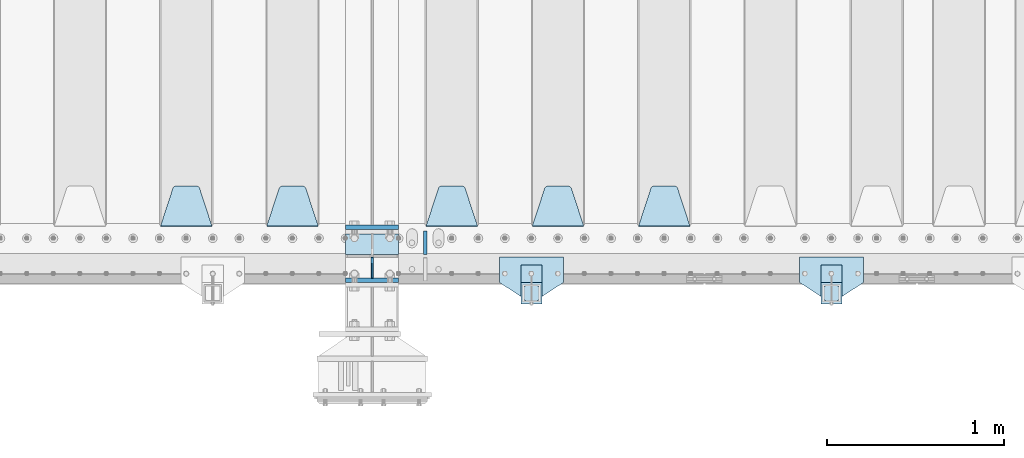
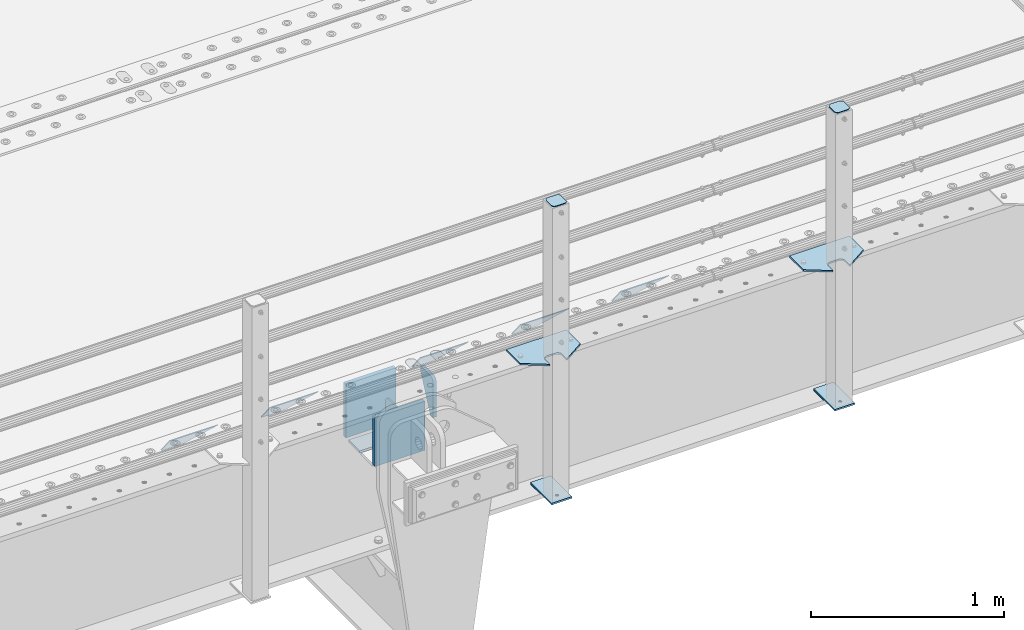
# One storey, part 179 of 208: 18 plates.
"""IFC2X3 building model written with IfcOpenShell, lengths in millimetres."""

from ifc_helpers import new_model, si_unit, frame, origin_with_axes, place, context, subcontext, project, spatial, faceted_brep, material, type_object, element, save


model = new_model("IFC2X3")

# Units and contexts
model_context = context("Model", 3, precision=1e-05, world=origin_with_axes())
body_context = subcontext(model_context, "Body", "Model", "MODEL_VIEW")
ifc_project = project(units=[si_unit("LENGTHUNIT", "METRE", prefix="MILLI"), si_unit("AREAUNIT", "SQUARE_METRE"), si_unit("VOLUMEUNIT", "CUBIC_METRE"), si_unit("MASSUNIT", "GRAM", prefix="KILO"), si_unit("TIMEUNIT", "SECOND"), si_unit("PLANEANGLEUNIT", "RADIAN"), si_unit("SOLIDANGLEUNIT", "STERADIAN"), si_unit("THERMODYNAMICTEMPERATUREUNIT", "DEGREE_CELSIUS"), si_unit("LUMINOUSINTENSITYUNIT", "LUMEN")], contexts=[model_context])

# Site, building, storey
site_placement = place(None, origin_with_axes())
site = spatial("IfcSite", under=ifc_project, at=site_placement, CompositionType="ELEMENT")
building_placement = place(site_placement, origin_with_axes())
building = spatial("IfcBuilding", under=site, at=building_placement, Name="Standard", CompositionType="ELEMENT")
storey_placement = place(building_placement, origin_with_axes())
storey = spatial("IfcBuildingStorey", under=building, at=storey_placement, Name="Undefined", CompositionType="ELEMENT", Elevation=0.0)

# Plates
ifc_material_1 = material(Name="STEEL/S355N")
plate_type_1 = type_object("IfcPlateType", PredefinedType="NOTDEFINED")
plate_1_placement = place(storey_placement, frame((-30350.0, 162.5, -340.000000000044), z_axis=(0.0, 0.0, 1.0), x_axis=(1.0, 0.0, 0.0)))
element("IfcPlate", 1, at=plate_1_placement, inside=storey, type_object=plate_type_1, material=ifc_material_1, context=body_context, shape_type="Brep", body=[
    faceted_brep([(0.0, -12.5, 0.0), (0.0, -12.5, 340.0), (0.0, 12.5, 340.0), (0.0, 12.5, 0.0), (300.0, -12.5, 340.0), (300.0, 12.5, 340.0), (300.0, -12.5, 0.0), (300.0, 12.5, 0.0)], [[[0, 1, 2, 3]], [[1, 4, 5, 2]], [[4, 6, 7, 5]], [[6, 0, 3, 7]], [[5, 7, 3, 2]], [[6, 4, 1, 0]]]),
])
plate_2_placement = place(storey_placement, frame((-30350.0, -137.5, -340.0), z_axis=(0.0, 0.0, 1.0), x_axis=(1.0, 0.0, 0.0)))
element("IfcPlate", 2, at=plate_2_placement, inside=storey, type_object=plate_type_1, material=ifc_material_1, context=body_context, shape_type="Brep", body=[
    faceted_brep([(0.0, -12.5, 0.0), (0.0, -12.5, 310.0), (0.0, 12.5, 310.0), (0.0, 12.5, 0.0), (300.0, -12.5, 310.0), (300.0, 12.5, 310.0), (300.0, -12.5, 0.0), (300.0, 12.5, 0.0)], [[[0, 1, 2, 3]], [[1, 4, 5, 2]], [[4, 6, 7, 5]], [[6, 0, 3, 7]], [[5, 7, 3, 2]], [[6, 4, 1, 0]]]),
])
plate_type_2 = type_object("IfcPlateType", PredefinedType="NOTDEFINED")
plate_3_placement = place(storey_placement, frame((-30350.0, 8.0, -343.0), z_axis=(0.0, 1.0, 0.0), x_axis=(1.0, 0.0, 0.0)))
element("IfcPlate", 3, at=plate_3_placement, inside=storey, type_object=plate_type_2, material=ifc_material_1, context=body_context, shape_type="Brep", body=[
    faceted_brep([(0.0, -7.0, 0.0), (0.0, -7.0, 117.0), (0.0, 7.0, 117.0), (0.0, 7.0, 0.0), (300.0, -7.0, 117.0), (300.0, 7.0, 117.0), (300.0, -7.0, 0.0), (300.0, 7.0, 0.0)], [[[0, 1, 2, 3]], [[1, 4, 5, 2]], [[4, 6, 7, 5]], [[6, 0, 3, 7]], [[5, 7, 3, 2]], [[6, 4, 1, 0]]]),
])
plate_type_3 = type_object("IfcPlateType", PredefinedType="NOTDEFINED")
plate_4_placement = place(storey_placement, frame((-30200.0, -8.0, -30.0), z_axis=(0.0, 0.0, -1.0), x_axis=(0.0, -1.0, 0.0)))
element("IfcPlate", 4, at=plate_4_placement, inside=storey, type_object=plate_type_3, material=ifc_material_1, context=body_context, shape_type="Brep", body=[
    faceted_brep([(0.0, -5.0, 30.0), (0.0, -5.0, 306.0), (0.0, 5.0, 306.0), (0.0, 5.0, 30.0), (117.0, -5.0, 306.0), (117.0, 5.0, 306.0), (117.0, -5.0, 0.0), (117.0, 5.0, 0.0), (30.0, -5.0, 0.0), (30.0, 5.0, 0.0), (24.7905546699922, -5.0, 0.455767409633758), (24.7905546699922, 5.0, 0.455767409633758), (19.7393957002296, -5.0, 1.80922137642275), (19.7393957002296, 5.0, 1.80922137642275), (15.0, -5.0, 4.01923788646684), (15.0, 5.0, 4.01923788646684), (10.7163717094036, -5.0, 7.01866670643066), (10.7163717094036, 5.0, 7.01866670643066), (7.01866670643085, -5.0, 10.7163717094038), (7.01866670643085, 5.0, 10.7163717094038), (4.01923788646673, -5.0, 15.0), (4.01923788646673, 5.0, 15.0), (1.80922137642301, -5.0, 19.7393957002299), (1.80922137642301, 5.0, 19.7393957002299), (0.455767409634063, -5.0, 24.7905546699921), (0.455767409634063, 5.0, 24.7905546699921)], [[[0, 1, 2, 3]], [[1, 4, 5, 2]], [[4, 6, 7, 5]], [[6, 8, 9, 7]], [[8, 10, 11, 9]], [[10, 12, 13, 11]], [[12, 14, 15, 13]], [[14, 16, 17, 15]], [[16, 18, 19, 17]], [[18, 20, 21, 19]], [[20, 22, 23, 21]], [[22, 24, 25, 23]], [[24, 0, 3, 25]], [[5, 7, 9, 11, 13, 15, 17, 19, 21, 23, 25, 3, 2]], [[24, 22, 20, 18, 16, 14, 12, 10, 8, 6, 4, 1, 0]]]),
])
plate_type_4 = type_object("IfcPlateType", PredefinedType="NOTDEFINED")
plate_5_placement = place(storey_placement, frame((-28405.0, 168.232233047019, -1.76776695296758), z_axis=(0.0, 0.707106781186547, -0.707106781186548), x_axis=(-1.0, 0.0, 0.0)))
element("IfcPlate", 5, at=plate_5_placement, inside=storey, type_object=plate_type_4, material=ifc_material_1, context=body_context, shape_type="Brep", body=[
    faceted_brep([(0.0, -2.5, 0.0), (69.345504679477, -2.5, 300.17173142483), (69.345504679477, 2.5, 300.17173142483), (0.0, 2.5, 0.0), (70.9274061199576, -2.5, 304.897442415399), (70.9274061199576, 2.5, 304.8974424154), (73.3818627772307, -2.5, 309.234538108527), (73.3818627772307, 2.5, 309.234538108527), (76.6187032999551, -2.5, 313.023683126103), (76.6187032999551, 2.5, 313.023683126103), (80.5190132704993, -2.5, 316.125672595371), (80.5190132704993, 2.5, 316.125672595371), (84.9395038596849, -2.5, 318.426546230476), (84.9395038596849, 2.50000000000091, 318.426546230476), (89.7177759439219, -2.5, 319.841774983275), (89.7177759439219, 2.50000000000091, 319.841774983275), (94.678286292652, -2.49999999999909, 320.319366455078), (94.678286292652, 2.5, 320.319366455078), (195.321713707348, -2.49999999999909, 320.319366455078), (195.321713707348, 2.5, 320.319366455078), (200.282224056078, -2.5, 319.841774983275), (200.282224056078, 2.5, 319.841774983274), (205.060496140315, -2.5, 318.426546230475), (205.060496140315, 2.5, 318.426546230475), (209.480986729501, -2.5, 316.125672595371), (209.480986729501, 2.50000000000091, 316.125672595371), (213.381296700045, -2.5, 313.023683126102), (213.381296700045, 2.5, 313.023683126102), (216.618137222769, -2.5, 309.234538108526), (216.618137222769, 2.5, 309.234538108527), (219.072593880042, -2.5, 304.897442415399), (219.072593880042, 2.5, 304.897442415399), (220.654495320523, -2.5, 300.17173142483), (220.654495320523, 2.5, 300.17173142483), (290.0, -2.5, 0.0), (290.0, 2.5, 0.0)], [[[0, 1, 2, 3]], [[1, 4, 5, 2]], [[4, 6, 7, 5]], [[6, 8, 9, 7]], [[8, 10, 11, 9]], [[10, 12, 13, 11]], [[12, 14, 15, 13]], [[14, 16, 17, 15]], [[16, 18, 19, 17]], [[18, 20, 21, 19]], [[20, 22, 23, 21]], [[22, 24, 25, 23]], [[24, 26, 27, 25]], [[26, 28, 29, 27]], [[28, 30, 31, 29]], [[30, 32, 33, 31]], [[32, 34, 35, 33]], [[34, 0, 3, 35]], [[5, 7, 9, 11, 13, 15, 17, 19, 21, 23, 25, 27, 29, 31, 33, 35, 3, 2]], [[34, 32, 30, 28, 26, 24, 22, 20, 18, 16, 14, 12, 10, 8, 6, 4, 1, 0]]]),
])
plate_6_placement = place(storey_placement, frame((-29005.0, 168.232233047019, -1.76776695296758), z_axis=(0.0, 0.707106781186547, -0.707106781186548), x_axis=(-1.0, 0.0, 0.0)))
element("IfcPlate", 6, at=plate_6_placement, inside=storey, type_object=plate_type_4, material=ifc_material_1, context=body_context, shape_type="Brep", body=[
    faceted_brep([(0.0, -2.5, 0.0), (69.345504679477, -2.5, 300.17173142483), (69.345504679477, 2.5, 300.17173142483), (0.0, 2.5, 0.0), (70.9274061199576, -2.5, 304.897442415399), (70.9274061199576, 2.5, 304.8974424154), (73.3818627772307, -2.5, 309.234538108527), (73.3818627772307, 2.5, 309.234538108527), (76.6187032999551, -2.5, 313.023683126103), (76.6187032999551, 2.5, 313.023683126103), (80.5190132704993, -2.5, 316.125672595371), (80.5190132704993, 2.5, 316.125672595371), (84.9395038596849, -2.5, 318.426546230476), (84.9395038596849, 2.50000000000091, 318.426546230476), (89.7177759439219, -2.5, 319.841774983275), (89.7177759439219, 2.50000000000091, 319.841774983275), (94.678286292652, -2.49999999999909, 320.319366455078), (94.678286292652, 2.5, 320.319366455078), (195.321713707348, -2.49999999999909, 320.319366455078), (195.321713707348, 2.5, 320.319366455078), (200.282224056078, -2.5, 319.841774983275), (200.282224056078, 2.5, 319.841774983274), (205.060496140315, -2.5, 318.426546230475), (205.060496140315, 2.5, 318.426546230475), (209.480986729501, -2.5, 316.125672595371), (209.480986729501, 2.50000000000091, 316.125672595371), (213.381296700045, -2.5, 313.023683126102), (213.381296700045, 2.5, 313.023683126102), (216.618137222769, -2.5, 309.234538108526), (216.618137222769, 2.5, 309.234538108527), (219.072593880042, -2.5, 304.897442415399), (219.072593880042, 2.5, 304.897442415399), (220.654495320523, -2.5, 300.17173142483), (220.654495320523, 2.5, 300.17173142483), (290.0, -2.5, 0.0), (290.0, 2.5, 0.0)], [[[0, 1, 2, 3]], [[1, 4, 5, 2]], [[4, 6, 7, 5]], [[6, 8, 9, 7]], [[8, 10, 11, 9]], [[10, 12, 13, 11]], [[12, 14, 15, 13]], [[14, 16, 17, 15]], [[16, 18, 19, 17]], [[18, 20, 21, 19]], [[20, 22, 23, 21]], [[22, 24, 25, 23]], [[24, 26, 27, 25]], [[26, 28, 29, 27]], [[28, 30, 31, 29]], [[30, 32, 33, 31]], [[32, 34, 35, 33]], [[34, 0, 3, 35]], [[5, 7, 9, 11, 13, 15, 17, 19, 21, 23, 25, 27, 29, 31, 33, 35, 3, 2]], [[34, 32, 30, 28, 26, 24, 22, 20, 18, 16, 14, 12, 10, 8, 6, 4, 1, 0]]]),
])
plate_7_placement = place(storey_placement, frame((-29605.0, 168.232233047019, -1.76776695296758), z_axis=(0.0, 0.707106781186547, -0.707106781186548), x_axis=(-1.0, 0.0, 0.0)))
element("IfcPlate", 7, at=plate_7_placement, inside=storey, type_object=plate_type_4, material=ifc_material_1, context=body_context, shape_type="Brep", body=[
    faceted_brep([(0.0, -2.5, 0.0), (69.345504679477, -2.5, 300.17173142483), (69.345504679477, 2.5, 300.17173142483), (0.0, 2.5, 0.0), (70.9274061199576, -2.5, 304.897442415399), (70.9274061199576, 2.5, 304.8974424154), (73.3818627772307, -2.5, 309.234538108527), (73.3818627772307, 2.5, 309.234538108527), (76.6187032999551, -2.5, 313.023683126103), (76.6187032999551, 2.5, 313.023683126103), (80.5190132704993, -2.5, 316.125672595371), (80.5190132704993, 2.5, 316.125672595371), (84.9395038596849, -2.5, 318.426546230476), (84.9395038596849, 2.50000000000091, 318.426546230476), (89.7177759439219, -2.5, 319.841774983275), (89.7177759439219, 2.50000000000091, 319.841774983275), (94.678286292652, -2.49999999999909, 320.319366455078), (94.678286292652, 2.5, 320.319366455078), (195.321713707348, -2.49999999999909, 320.319366455078), (195.321713707348, 2.5, 320.319366455078), (200.282224056078, -2.5, 319.841774983275), (200.282224056078, 2.5, 319.841774983274), (205.060496140315, -2.5, 318.426546230475), (205.060496140315, 2.5, 318.426546230475), (209.480986729501, -2.5, 316.125672595371), (209.480986729501, 2.50000000000091, 316.125672595371), (213.381296700045, -2.5, 313.023683126102), (213.381296700045, 2.5, 313.023683126102), (216.618137222769, -2.5, 309.234538108526), (216.618137222769, 2.5, 309.234538108527), (219.072593880042, -2.5, 304.897442415399), (219.072593880042, 2.5, 304.897442415399), (220.654495320523, -2.5, 300.17173142483), (220.654495320523, 2.5, 300.17173142483), (290.0, -2.5, 0.0), (290.0, 2.5, 0.0)], [[[0, 1, 2, 3]], [[1, 4, 5, 2]], [[4, 6, 7, 5]], [[6, 8, 9, 7]], [[8, 10, 11, 9]], [[10, 12, 13, 11]], [[12, 14, 15, 13]], [[14, 16, 17, 15]], [[16, 18, 19, 17]], [[18, 20, 21, 19]], [[20, 22, 23, 21]], [[22, 24, 25, 23]], [[24, 26, 27, 25]], [[26, 28, 29, 27]], [[28, 30, 31, 29]], [[30, 32, 33, 31]], [[32, 34, 35, 33]], [[34, 0, 3, 35]], [[5, 7, 9, 11, 13, 15, 17, 19, 21, 23, 25, 27, 29, 31, 33, 35, 3, 2]], [[34, 32, 30, 28, 26, 24, 22, 20, 18, 16, 14, 12, 10, 8, 6, 4, 1, 0]]]),
])
plate_8_placement = place(storey_placement, frame((-30505.0, 168.232233047019, -1.76776695296758), z_axis=(0.0, 0.707106781186547, -0.707106781186548), x_axis=(-1.0, 0.0, 0.0)))
element("IfcPlate", 8, at=plate_8_placement, inside=storey, type_object=plate_type_4, material=ifc_material_1, context=body_context, shape_type="Brep", body=[
    faceted_brep([(0.0, -2.5, 0.0), (69.345504679477, -2.5, 300.17173142483), (69.345504679477, 2.5, 300.17173142483), (0.0, 2.5, 0.0), (70.9274061199576, -2.5, 304.897442415399), (70.9274061199576, 2.5, 304.8974424154), (73.3818627772307, -2.5, 309.234538108527), (73.3818627772307, 2.5, 309.234538108527), (76.6187032999551, -2.5, 313.023683126103), (76.6187032999551, 2.5, 313.023683126103), (80.5190132704993, -2.5, 316.125672595371), (80.5190132704993, 2.5, 316.125672595371), (84.9395038596849, -2.5, 318.426546230476), (84.9395038596849, 2.50000000000091, 318.426546230476), (89.7177759439219, -2.5, 319.841774983275), (89.7177759439219, 2.50000000000091, 319.841774983275), (94.678286292652, -2.49999999999909, 320.319366455078), (94.678286292652, 2.5, 320.319366455078), (195.321713707348, -2.49999999999909, 320.319366455078), (195.321713707348, 2.5, 320.319366455078), (200.282224056078, -2.5, 319.841774983275), (200.282224056078, 2.5, 319.841774983274), (205.060496140315, -2.5, 318.426546230475), (205.060496140315, 2.5, 318.426546230475), (209.480986729501, -2.5, 316.125672595371), (209.480986729501, 2.50000000000091, 316.125672595371), (213.381296700045, -2.5, 313.023683126102), (213.381296700045, 2.5, 313.023683126102), (216.618137222769, -2.5, 309.234538108526), (216.618137222769, 2.5, 309.234538108527), (219.072593880042, -2.5, 304.897442415399), (219.072593880042, 2.5, 304.897442415399), (220.654495320523, -2.5, 300.17173142483), (220.654495320523, 2.5, 300.17173142483), (290.0, -2.5, 0.0), (290.0, 2.5, 0.0)], [[[0, 1, 2, 3]], [[1, 4, 5, 2]], [[4, 6, 7, 5]], [[6, 8, 9, 7]], [[8, 10, 11, 9]], [[10, 12, 13, 11]], [[12, 14, 15, 13]], [[14, 16, 17, 15]], [[16, 18, 19, 17]], [[18, 20, 21, 19]], [[20, 22, 23, 21]], [[22, 24, 25, 23]], [[24, 26, 27, 25]], [[26, 28, 29, 27]], [[28, 30, 31, 29]], [[30, 32, 33, 31]], [[32, 34, 35, 33]], [[34, 0, 3, 35]], [[5, 7, 9, 11, 13, 15, 17, 19, 21, 23, 25, 27, 29, 31, 33, 35, 3, 2]], [[34, 32, 30, 28, 26, 24, 22, 20, 18, 16, 14, 12, 10, 8, 6, 4, 1, 0]]]),
])
plate_9_placement = place(storey_placement, frame((-31105.0, 168.232233047019, -1.76776695296758), z_axis=(0.0, 0.707106781186547, -0.707106781186548), x_axis=(-1.0, 0.0, 0.0)))
element("IfcPlate", 9, at=plate_9_placement, inside=storey, type_object=plate_type_4, material=ifc_material_1, context=body_context, shape_type="Brep", body=[
    faceted_brep([(0.0, -2.5, 0.0), (69.345504679477, -2.5, 300.17173142483), (69.345504679477, 2.5, 300.17173142483), (0.0, 2.5, 0.0), (70.9274061199576, -2.5, 304.897442415399), (70.9274061199576, 2.5, 304.8974424154), (73.3818627772307, -2.5, 309.234538108527), (73.3818627772307, 2.5, 309.234538108527), (76.6187032999551, -2.5, 313.023683126103), (76.6187032999551, 2.5, 313.023683126103), (80.5190132704993, -2.5, 316.125672595371), (80.5190132704993, 2.5, 316.125672595371), (84.9395038596849, -2.5, 318.426546230476), (84.9395038596849, 2.50000000000091, 318.426546230476), (89.7177759439219, -2.5, 319.841774983275), (89.7177759439219, 2.50000000000091, 319.841774983275), (94.678286292652, -2.49999999999909, 320.319366455078), (94.678286292652, 2.5, 320.319366455078), (195.321713707348, -2.49999999999909, 320.319366455078), (195.321713707348, 2.5, 320.319366455078), (200.282224056078, -2.5, 319.841774983275), (200.282224056078, 2.5, 319.841774983274), (205.060496140315, -2.5, 318.426546230475), (205.060496140315, 2.5, 318.426546230475), (209.480986729501, -2.5, 316.125672595371), (209.480986729501, 2.50000000000091, 316.125672595371), (213.381296700045, -2.5, 313.023683126102), (213.381296700045, 2.5, 313.023683126102), (216.618137222769, -2.5, 309.234538108526), (216.618137222769, 2.5, 309.234538108527), (219.072593880042, -2.5, 304.897442415399), (219.072593880042, 2.5, 304.897442415399), (220.654495320523, -2.5, 300.17173142483), (220.654495320523, 2.5, 300.17173142483), (290.0, -2.5, 0.0), (290.0, 2.5, 0.0)], [[[0, 1, 2, 3]], [[1, 4, 5, 2]], [[4, 6, 7, 5]], [[6, 8, 9, 7]], [[8, 10, 11, 9]], [[10, 12, 13, 11]], [[12, 14, 15, 13]], [[14, 16, 17, 15]], [[16, 18, 19, 17]], [[18, 20, 21, 19]], [[20, 22, 23, 21]], [[22, 24, 25, 23]], [[24, 26, 27, 25]], [[26, 28, 29, 27]], [[28, 30, 31, 29]], [[30, 32, 33, 31]], [[32, 34, 35, 33]], [[34, 0, 3, 35]], [[5, 7, 9, 11, 13, 15, 17, 19, 21, 23, 25, 27, 29, 31, 33, 35, 3, 2]], [[34, 32, 30, 28, 26, 24, 22, 20, 18, 16, 14, 12, 10, 8, 6, 4, 1, 0]]]),
])
plate_type_5 = type_object("IfcPlateType", PredefinedType="NOTDEFINED")
plate_10_placement = place(storey_placement, frame((-29900.0, 140.0, -30.0), z_axis=(0.0, 0.0, -1.0), x_axis=(0.0, -1.0, 0.0)))
element("IfcPlate", 10, at=plate_10_placement, inside=storey, type_object=plate_type_5, material=ifc_material_1, context=body_context, shape_type="Brep", body=[
    faceted_brep([(0.0, -10.0, 0.0), (0.0, -10.0, 30.0), (0.0, 10.0, 30.0), (0.0, 10.0, 0.0), (102.0, -10.0, 250.0), (102.0, 10.0, 250.0), (132.0, -10.0, 250.0), (132.0, 10.0, 250.0), (132.0, -10.0, 30.0), (132.0, 10.0, 30.0), (131.544232590366, -10.0, 24.790554669992), (131.544232590366, 10.0, 24.790554669992), (130.190778623577, -10.0, 19.7393957002299), (130.190778623577, 10.0, 19.7393957002299), (127.980762113533, -10.0, 15.0), (127.980762113533, 10.0, 15.0), (124.981333293569, -10.0, 10.7163717094038), (124.981333293569, 10.0, 10.7163717094038), (121.283628290596, -10.0, 7.01866670643062), (121.283628290596, 10.0, 7.01866670643062), (117.0, -10.0, 4.01923788646684), (117.0, 10.0, 4.01923788646684), (112.26060429977, -10.0, 1.80922137642278), (112.26060429977, 10.0, 1.80922137642278), (107.209445330008, -10.0, 0.455767409633722), (107.209445330008, 10.0, 0.455767409633722), (102.0, -10.0, 0.0), (102.0, 10.0, 0.0)], [[[0, 1, 2, 3]], [[1, 4, 5, 2]], [[4, 6, 7, 5]], [[6, 8, 9, 7]], [[8, 10, 11, 9]], [[10, 12, 13, 11]], [[12, 14, 15, 13]], [[14, 16, 17, 15]], [[16, 18, 19, 17]], [[18, 20, 21, 19]], [[20, 22, 23, 21]], [[22, 24, 25, 23]], [[24, 26, 27, 25]], [[26, 0, 3, 27]], [[5, 7, 9, 11, 13, 15, 17, 19, 21, 23, 25, 27, 3, 2]], [[26, 24, 22, 20, 18, 16, 14, 12, 10, 8, 6, 4, 1, 0]]]),
])
ifc_material_2 = material(Name="STEEL/S355J2")
plate_type_6 = type_object("IfcPlateType", PredefinedType="NOTDEFINED")
plate_11_placement = place(storey_placement, frame((-27425.0, -4.99999999999636, 5.00000000004911), z_axis=(0.0, -1.0, 0.0), x_axis=(-1.0, 0.0, 0.0)))
element("IfcPlate", 11, at=plate_11_placement, inside=storey, type_object=plate_type_6, material=ifc_material_2, context=body_context, shape_type="Brep", body=[
    faceted_brep([(0.0, -5.0, 0.0), (2.31396552408114e-06, -5.0, 145.0), (2.31396552408114e-06, 5.0, 145.0), (0.0, 5.0, 0.0), (130.0, -5.0, 230.0), (130.0, 5.0, 230.0), (130.0, -5.0, 180.0), (130.0, 5.0, 180.0), (130.48036798992, -5.0, 175.122741949597), (130.48036798992, 5.0, 175.122741949597), (131.903011687216, -5.0, 170.432914190873), (131.903011687216, 5.0, 170.432914190873), (134.213259692435, -5.0, 166.11074417451), (134.213259692435, 5.0, 166.11074417451), (137.322330470335, -5.0, 162.322330470336), (137.322330470335, 5.0, 162.322330470336), (141.110744174512, -5.0, 159.213259692437), (141.110744174512, 5.0, 159.213259692437), (145.432914190871, -5.0, 156.903011687218), (145.432914190871, 5.0, 156.903011687218), (150.122741949595, -5.0, 155.48036798992), (150.122741949595, 5.0, 155.48036798992), (155.0, -5.0, 155.0), (155.0, 5.0, 155.0), (205.0, -5.0, 155.0), (205.0, 5.0, 155.0), (209.877258050405, -5.0, 155.48036798992), (209.877258050405, 5.0, 155.48036798992), (214.567085809129, -5.0, 156.903011687218), (214.567085809129, 5.0, 156.903011687218), (218.889255825488, -5.0, 159.213259692437), (218.889255825488, 5.0, 159.213259692437), (222.677669529665, -5.0, 162.322330470336), (222.677669529665, 5.0, 162.322330470336), (225.786740307565, -5.0, 166.11074417451), (225.786740307565, 5.0, 166.11074417451), (228.096988312784, -5.0, 170.432914190873), (228.096988312784, 5.0, 170.432914190873), (229.51963201008, -5.0, 175.122741949597), (229.51963201008, 5.0, 175.122741949597), (230.0, -5.0, 180.0), (230.0, 5.0, 180.0), (230.0, -5.0, 230.0), (230.0, 5.0, 230.0), (360.0, -5.0, 145.0), (360.0, 5.0, 145.0), (360.0, -5.0, -7.27595761418343e-12), (360.0, 5.0, -7.27595761418343e-12)], [[[0, 1, 2, 3]], [[1, 4, 5, 2]], [[4, 6, 7, 5]], [[6, 8, 9, 7]], [[8, 10, 11, 9]], [[10, 12, 13, 11]], [[12, 14, 15, 13]], [[14, 16, 17, 15]], [[16, 18, 19, 17]], [[18, 20, 21, 19]], [[20, 22, 23, 21]], [[22, 24, 25, 23]], [[24, 26, 27, 25]], [[26, 28, 29, 27]], [[28, 30, 31, 29]], [[30, 32, 33, 31]], [[32, 34, 35, 33]], [[34, 36, 37, 35]], [[36, 38, 39, 37]], [[38, 40, 41, 39]], [[40, 42, 43, 41]], [[42, 44, 45, 43]], [[44, 46, 47, 45]], [[46, 0, 3, 47]], [[5, 7, 9, 11, 13, 15, 17, 19, 21, 23, 25, 27, 29, 31, 33, 35, 37, 39, 41, 43, 45, 47, 3, 2]], [[46, 44, 42, 40, 38, 36, 34, 32, 30, 28, 26, 24, 22, 20, 18, 16, 14, 12, 10, 8, 6, 4, 1, 0]]]),
])
plate_12_placement = place(storey_placement, frame((-29120.0, -4.99999999999636, 5.00000000004911), z_axis=(0.0, -1.0, 0.0), x_axis=(-1.0, 0.0, 0.0)))
element("IfcPlate", 12, at=plate_12_placement, inside=storey, type_object=plate_type_6, material=ifc_material_2, context=body_context, shape_type="Brep", body=[
    faceted_brep([(0.0, -5.0, 0.0), (2.31396552408114e-06, -5.0, 145.0), (2.31396552408114e-06, 5.0, 145.0), (0.0, 5.0, 0.0), (130.0, -5.0, 230.0), (130.0, 5.0, 230.0), (130.0, -5.0, 180.0), (130.0, 5.0, 180.0), (130.48036798992, -5.0, 175.122741949597), (130.48036798992, 5.0, 175.122741949597), (131.903011687216, -5.0, 170.432914190873), (131.903011687216, 5.0, 170.432914190873), (134.213259692435, -5.0, 166.11074417451), (134.213259692435, 5.0, 166.11074417451), (137.322330470335, -5.0, 162.322330470336), (137.322330470335, 5.0, 162.322330470336), (141.110744174512, -5.0, 159.213259692437), (141.110744174512, 5.0, 159.213259692437), (145.432914190871, -5.0, 156.903011687218), (145.432914190871, 5.0, 156.903011687218), (150.122741949595, -5.0, 155.48036798992), (150.122741949595, 5.0, 155.48036798992), (155.0, -5.0, 155.0), (155.0, 5.0, 155.0), (205.0, -5.0, 155.0), (205.0, 5.0, 155.0), (209.877258050405, -5.0, 155.48036798992), (209.877258050405, 5.0, 155.48036798992), (214.567085809129, -5.0, 156.903011687218), (214.567085809129, 5.0, 156.903011687218), (218.889255825488, -5.0, 159.213259692437), (218.889255825488, 5.0, 159.213259692437), (222.677669529665, -5.0, 162.322330470336), (222.677669529665, 5.0, 162.322330470336), (225.786740307565, -5.0, 166.11074417451), (225.786740307565, 5.0, 166.11074417451), (228.096988312784, -5.0, 170.432914190873), (228.096988312784, 5.0, 170.432914190873), (229.51963201008, -5.0, 175.122741949597), (229.51963201008, 5.0, 175.122741949597), (230.0, -5.0, 180.0), (230.0, 5.0, 180.0), (230.0, -5.0, 230.0), (230.0, 5.0, 230.0), (360.0, -5.0, 145.0), (360.0, 5.0, 145.0), (360.0, -5.0, -7.27595761418343e-12), (360.0, 5.0, -7.27595761418343e-12)], [[[0, 1, 2, 3]], [[1, 4, 5, 2]], [[4, 6, 7, 5]], [[6, 8, 9, 7]], [[8, 10, 11, 9]], [[10, 12, 13, 11]], [[12, 14, 15, 13]], [[14, 16, 17, 15]], [[16, 18, 19, 17]], [[18, 20, 21, 19]], [[20, 22, 23, 21]], [[22, 24, 25, 23]], [[24, 26, 27, 25]], [[26, 28, 29, 27]], [[28, 30, 31, 29]], [[30, 32, 33, 31]], [[32, 34, 35, 33]], [[34, 36, 37, 35]], [[36, 38, 39, 37]], [[38, 40, 41, 39]], [[40, 42, 43, 41]], [[42, 44, 45, 43]], [[44, 46, 47, 45]], [[46, 0, 3, 47]], [[5, 7, 9, 11, 13, 15, 17, 19, 21, 23, 25, 27, 29, 31, 33, 35, 37, 39, 41, 43, 45, 47, 3, 2]], [[46, 44, 42, 40, 38, 36, 34, 32, 30, 28, 26, 24, 22, 20, 18, 16, 14, 12, 10, 8, 6, 4, 1, 0]]]),
])
plate_type_7 = type_object("IfcPlateType", PredefinedType="NOTDEFINED")
for number, where, z_axis, x_axis in (
    (13, (-27545.0000000001, -50.0000000002074, -850.000000000002), (0.0, -1.0, 0.0), (-1.0, 0.0, 0.0)),
    (14, (-29240.0000000001, -50.0000000002074, -850.000000000002), (0.0, -1.0, 0.0), (-1.0, 0.0, 0.0)),
):
    element("IfcPlate", number, at=place(storey_placement, frame(where, z_axis=z_axis, x_axis=x_axis)), inside=storey, type_object=plate_type_7, material=ifc_material_2, context=body_context, shape_type="Brep", body=[
        faceted_brep([(53.6360389691836, -5.0, 176.36396103047), (53.6360389691836, 5.0, 176.36396103047), (59.9999999998618, 5.0, 178.999999999791), (59.9999999998618, -5.0, 178.999999999791), (66.3639610305399, 5.0, 176.36396103047), (66.3639610305399, -5.0, 176.36396103047), (68.9999999998618, 5.0, 169.999999999791), (68.9999999998618, -5.0, 169.999999999791), (66.3639610305399, 5.0, 163.636038969112), (66.3639610305399, -5.0, 163.636038969112), (59.9999999998618, 5.0, 160.999999999791), (59.9999999998618, -5.0, 160.999999999791), (53.6360389691836, 5.0, 163.636038969112), (53.6360389691836, -5.0, 163.636038969112), (50.9999999998618, 5.0, 169.999999999791), (50.9999999998618, -5.0, 169.999999999791), (120.0, -5.0, 0.0), (120.0, -5.0, 220.0), (0.0, -5.0, 220.0), (0.0, -5.0, 0.0), (0.0, 5.0, 0.0), (120.0, 5.0, 0.0), (120.0, 5.0, 220.0), (0.0, 5.0, 220.0)], [[[0, 1, 2, 3]], [[3, 2, 4, 5]], [[5, 4, 6, 7]], [[7, 6, 8, 9]], [[9, 8, 10, 11]], [[11, 10, 12, 13]], [[13, 12, 14, 15]], [[15, 14, 1, 0]], [[16, 17, 18, 19], [11, 13, 15, 0, 3, 5, 7, 9]], [[16, 19, 20, 21]], [[17, 16, 21, 22]], [[18, 17, 22, 23]], [[19, 18, 23, 20]], [[22, 21, 20, 23], [2, 1, 14, 12, 10, 8, 6, 4]]]),
    ])
plate_type_8 = type_object("IfcPlateType", PredefinedType="NOTDEFINED")
plate_13_placement = place(storey_placement, frame((-27649.0000000001, -166.000000000207, 1012.50000000001), z_axis=(0.0, -1.0, 0.0), x_axis=(1.0, 0.0, 0.0)))
element("IfcPlate", 15, at=plate_13_placement, inside=storey, type_object=plate_type_8, material=ifc_material_2, context=body_context, shape_type="Brep", body=[
    faceted_brep([(0.0, -2.5, 19.0), (0.0, -2.5, 69.0), (0.0, 2.5, 69.0), (0.0, 2.5, 19.0), (0.476369668544066, -2.5, 73.2278977451697), (0.476369668544066, 2.5, 73.2278977451697), (1.88159150985302, -2.5, 77.2437910432336), (1.88159150985302, 2.5, 77.2437910432336), (4.14520183310742, -2.5, 80.8463062353158), (4.14520183310742, 2.5, 80.8463062353158), (7.15369376468516, -2.5, 83.8547981668926), (7.15369376468516, 2.5, 83.8547981668926), (10.7562089567655, -2.5, 86.1184084901461), (10.7562089567655, 2.5, 86.1184084901461), (14.7721022548285, -2.5, 87.523630331455), (14.7721022548285, 2.5, 87.523630331455), (19.0, -2.5, 88.0), (19.0, 2.5, 88.0), (69.0, -2.5, 88.0), (69.0, 2.5, 88.0), (73.2278977451715, -2.5, 87.523630331455), (73.2278977451715, 2.5, 87.523630331455), (77.2437910432345, -2.5, 86.1184084901461), (77.2437910432345, 2.5, 86.1184084901461), (80.8463062353148, -2.5, 83.8547981668926), (80.8463062353148, 2.5, 83.8547981668926), (83.8547981668926, -2.5, 80.8463062353158), (83.8547981668926, 2.5, 80.8463062353158), (86.118408490147, -2.5, 77.2437910432336), (86.118408490147, 2.5, 77.2437910432336), (87.5236303314559, -2.5, 73.2278977451697), (87.5236303314559, 2.5, 73.2278977451697), (88.0, -2.5, 69.0), (88.0, 2.5, 69.0), (88.0, -2.5, 19.0), (88.0, 2.5, 19.0), (87.5236303314559, -2.5, 14.7721022548303), (87.5236303314559, 2.5, 14.7721022548303), (86.118408490147, -2.5, 10.7562089567664), (86.118408490147, 2.5, 10.7562089567664), (83.8547981668926, -2.5, 7.15369376468425), (83.8547981668926, 2.5, 7.15369376468425), (80.8463062353148, -2.5, 4.14520183310742), (80.8463062353148, 2.5, 4.14520183310742), (77.2437910432345, -2.5, 1.88159150985393), (77.2437910432345, 2.5, 1.88159150985393), (73.2278977451715, -2.5, 0.476369668544976), (73.2278977451715, 2.5, 0.476369668544976), (69.0, -2.5, 0.0), (69.0, 2.5, 0.0), (19.0, -2.5, 0.0), (19.0, 2.5, 0.0), (14.7721022548285, -2.5, 0.476369668544976), (14.7721022548285, 2.5, 0.476369668544976), (10.7562089567655, -2.5, 1.88159150985393), (10.7562089567655, 2.5, 1.88159150985393), (7.15369376468516, -2.5, 4.14520183310742), (7.15369376468516, 2.5, 4.14520183310742), (4.14520183310742, -2.5, 7.15369376468425), (4.14520183310742, 2.5, 7.15369376468425), (1.88159150985302, -2.5, 10.7562089567664), (1.88159150985302, 2.5, 10.7562089567664), (0.476369668544066, -2.5, 14.7721022548303), (0.476369668544066, 2.5, 14.7721022548303)], [[[0, 1, 2, 3]], [[1, 4, 5, 2]], [[4, 6, 7, 5]], [[6, 8, 9, 7]], [[8, 10, 11, 9]], [[10, 12, 13, 11]], [[12, 14, 15, 13]], [[14, 16, 17, 15]], [[16, 18, 19, 17]], [[18, 20, 21, 19]], [[20, 22, 23, 21]], [[22, 24, 25, 23]], [[24, 26, 27, 25]], [[26, 28, 29, 27]], [[28, 30, 31, 29]], [[30, 32, 33, 31]], [[32, 34, 35, 33]], [[34, 36, 37, 35]], [[36, 38, 39, 37]], [[38, 40, 41, 39]], [[40, 42, 43, 41]], [[42, 44, 45, 43]], [[44, 46, 47, 45]], [[46, 48, 49, 47]], [[48, 50, 51, 49]], [[50, 52, 53, 51]], [[52, 54, 55, 53]], [[54, 56, 57, 55]], [[56, 58, 59, 57]], [[58, 60, 61, 59]], [[60, 62, 63, 61]], [[62, 0, 3, 63]], [[5, 7, 9, 11, 13, 15, 17, 19, 21, 23, 25, 27, 29, 31, 33, 35, 37, 39, 41, 43, 45, 47, 49, 51, 53, 55, 57, 59, 61, 63, 3, 2]], [[62, 60, 58, 56, 54, 52, 50, 48, 46, 44, 42, 40, 38, 36, 34, 32, 30, 28, 26, 24, 22, 20, 18, 16, 14, 12, 10, 8, 6, 4, 1, 0]]]),
])
plate_14_placement = place(storey_placement, frame((-29344.0000000001, -166.000000000207, 1012.50000000001), z_axis=(0.0, -1.0, 0.0), x_axis=(1.0, 0.0, 0.0)))
element("IfcPlate", 16, at=plate_14_placement, inside=storey, type_object=plate_type_8, material=ifc_material_2, context=body_context, shape_type="Brep", body=[
    faceted_brep([(0.0, -2.5, 19.0), (0.0, -2.5, 69.0), (0.0, 2.5, 69.0), (0.0, 2.5, 19.0), (0.476369668544066, -2.5, 73.2278977451697), (0.476369668544066, 2.5, 73.2278977451697), (1.88159150985302, -2.5, 77.2437910432336), (1.88159150985302, 2.5, 77.2437910432336), (4.14520183310742, -2.5, 80.8463062353158), (4.14520183310742, 2.5, 80.8463062353158), (7.15369376468516, -2.5, 83.8547981668926), (7.15369376468516, 2.5, 83.8547981668926), (10.7562089567655, -2.5, 86.1184084901461), (10.7562089567655, 2.5, 86.1184084901461), (14.7721022548285, -2.5, 87.523630331455), (14.7721022548285, 2.5, 87.523630331455), (19.0, -2.5, 88.0), (19.0, 2.5, 88.0), (69.0, -2.5, 88.0), (69.0, 2.5, 88.0), (73.2278977451715, -2.5, 87.523630331455), (73.2278977451715, 2.5, 87.523630331455), (77.2437910432345, -2.5, 86.1184084901461), (77.2437910432345, 2.5, 86.1184084901461), (80.8463062353148, -2.5, 83.8547981668926), (80.8463062353148, 2.5, 83.8547981668926), (83.8547981668926, -2.5, 80.8463062353158), (83.8547981668926, 2.5, 80.8463062353158), (86.118408490147, -2.5, 77.2437910432336), (86.118408490147, 2.5, 77.2437910432336), (87.5236303314559, -2.5, 73.2278977451697), (87.5236303314559, 2.5, 73.2278977451697), (88.0, -2.5, 69.0), (88.0, 2.5, 69.0), (88.0, -2.5, 19.0), (88.0, 2.5, 19.0), (87.5236303314559, -2.5, 14.7721022548303), (87.5236303314559, 2.5, 14.7721022548303), (86.118408490147, -2.5, 10.7562089567664), (86.118408490147, 2.5, 10.7562089567664), (83.8547981668926, -2.5, 7.15369376468425), (83.8547981668926, 2.5, 7.15369376468425), (80.8463062353148, -2.5, 4.14520183310742), (80.8463062353148, 2.5, 4.14520183310742), (77.2437910432345, -2.5, 1.88159150985393), (77.2437910432345, 2.5, 1.88159150985393), (73.2278977451715, -2.5, 0.476369668544976), (73.2278977451715, 2.5, 0.476369668544976), (69.0, -2.5, 0.0), (69.0, 2.5, 0.0), (19.0, -2.5, 0.0), (19.0, 2.5, 0.0), (14.7721022548285, -2.5, 0.476369668544976), (14.7721022548285, 2.5, 0.476369668544976), (10.7562089567655, -2.5, 1.88159150985393), (10.7562089567655, 2.5, 1.88159150985393), (7.15369376468516, -2.5, 4.14520183310742), (7.15369376468516, 2.5, 4.14520183310742), (4.14520183310742, -2.5, 7.15369376468425), (4.14520183310742, 2.5, 7.15369376468425), (1.88159150985302, -2.5, 10.7562089567664), (1.88159150985302, 2.5, 10.7562089567664), (0.476369668544066, -2.5, 14.7721022548303), (0.476369668544066, 2.5, 14.7721022548303)], [[[0, 1, 2, 3]], [[1, 4, 5, 2]], [[4, 6, 7, 5]], [[6, 8, 9, 7]], [[8, 10, 11, 9]], [[10, 12, 13, 11]], [[12, 14, 15, 13]], [[14, 16, 17, 15]], [[16, 18, 19, 17]], [[18, 20, 21, 19]], [[20, 22, 23, 21]], [[22, 24, 25, 23]], [[24, 26, 27, 25]], [[26, 28, 29, 27]], [[28, 30, 31, 29]], [[30, 32, 33, 31]], [[32, 34, 35, 33]], [[34, 36, 37, 35]], [[36, 38, 39, 37]], [[38, 40, 41, 39]], [[40, 42, 43, 41]], [[42, 44, 45, 43]], [[44, 46, 47, 45]], [[46, 48, 49, 47]], [[48, 50, 51, 49]], [[50, 52, 53, 51]], [[52, 54, 55, 53]], [[54, 56, 57, 55]], [[56, 58, 59, 57]], [[58, 60, 61, 59]], [[60, 62, 63, 61]], [[62, 0, 3, 63]], [[5, 7, 9, 11, 13, 15, 17, 19, 21, 23, 25, 27, 29, 31, 33, 35, 37, 39, 41, 43, 45, 47, 49, 51, 53, 55, 57, 59, 61, 63, 3, 2]], [[62, 60, 58, 56, 54, 52, 50, 48, 46, 44, 42, 40, 38, 36, 34, 32, 30, 28, 26, 24, 22, 20, 18, 16, 14, 12, 10, 8, 6, 4, 1, 0]]]),
])
plate_type_9 = type_object("IfcPlateType", PredefinedType="NOTDEFINED")
for number, where, z_axis, x_axis in (
    (17, (-27545.0000000001, -50.0000000002074, -857.500000000002), (0.0, -1.0, 0.0), (-1.0, 0.0, 0.0)),
    (18, (-29240.0000000001, -50.0000000002074, -857.500000000002), (0.0, -1.0, 0.0), (-1.0, 0.0, 0.0)),
):
    element("IfcPlate", number, at=place(storey_placement, frame(where, z_axis=z_axis, x_axis=x_axis)), inside=storey, type_object=plate_type_9, material=ifc_material_2, context=body_context, shape_type="Brep", body=[
        faceted_brep([(0.0, -2.5, 0.0), (0.0, -2.5, 100.0), (0.0, 2.5, 100.0), (0.0, 2.5, 0.0), (120.0, -2.5, 100.0), (120.0, 2.5, 100.0), (120.0, -2.5, 0.0), (120.0, 2.5, 0.0)], [[[0, 1, 2, 3]], [[1, 4, 5, 2]], [[4, 6, 7, 5]], [[6, 0, 3, 7]], [[5, 7, 3, 2]], [[6, 4, 1, 0]]]),
    ])

save(model, "model.ifc")
